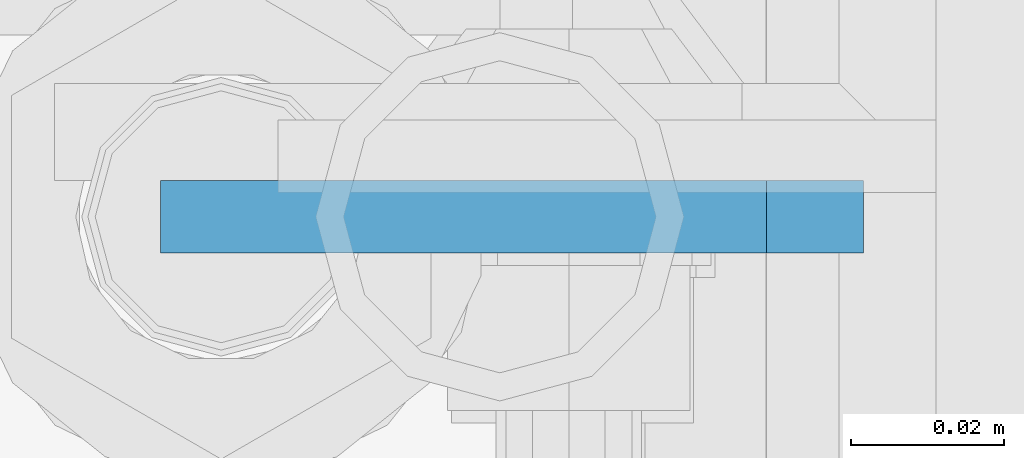
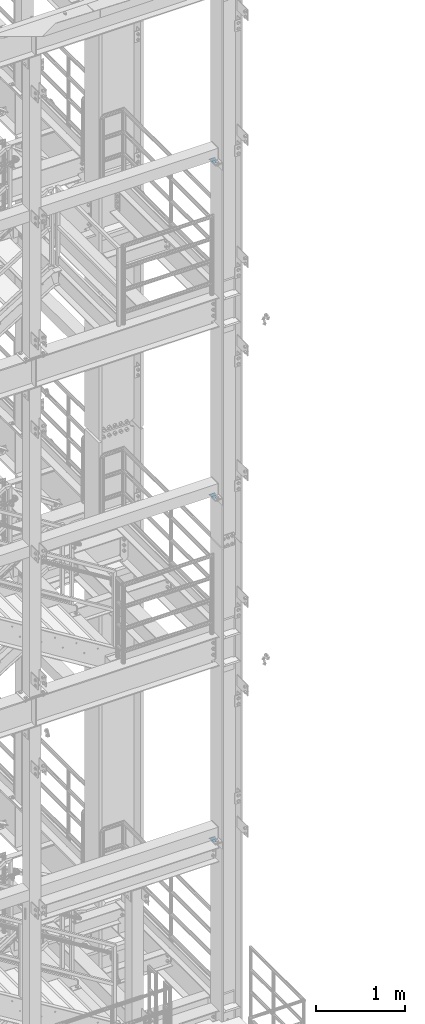
# One storey, part 1454 of 1876: 3 plates, 2 elements without a shape of their own.
"""IFC2X3 building model written with IfcOpenShell, lengths in millimetres."""

from ifc_helpers import new_model, si_unit, frame, origin_with_axes, place, context, subcontext, project, spatial, faceted_brep, material, type_object, element, aggregate, save


model = new_model("IFC2X3")

# Units and contexts
model_context = context("Model", 3, precision=1e-05, world=origin_with_axes())
body_context = subcontext(model_context, "Body", "Model", "MODEL_VIEW")
ifc_project = project(units=[si_unit("LENGTHUNIT", "METRE", prefix="MILLI"), si_unit("AREAUNIT", "SQUARE_METRE"), si_unit("VOLUMEUNIT", "CUBIC_METRE"), si_unit("MASSUNIT", "GRAM", prefix="KILO"), si_unit("TIMEUNIT", "SECOND"), si_unit("PLANEANGLEUNIT", "RADIAN"), si_unit("SOLIDANGLEUNIT", "STERADIAN"), si_unit("THERMODYNAMICTEMPERATUREUNIT", "DEGREE_CELSIUS"), si_unit("LUMINOUSINTENSITYUNIT", "LUMEN")], contexts=[model_context])

# Site, building, storey
site_placement = place(None, origin_with_axes())
site = spatial("IfcSite", under=ifc_project, at=site_placement, CompositionType="ELEMENT")
building_placement = place(site_placement, origin_with_axes())
building = spatial("IfcBuilding", under=site, at=building_placement, Name="Undefined", CompositionType="ELEMENT")
storey_placement = place(building_placement, origin_with_axes())
storey = spatial("IfcBuildingStorey", under=building, at=storey_placement, Name="Undefined", CompositionType="ELEMENT", Elevation=0.0)

# Assembly, plates
assembly_1_placement = place(storey_placement, origin_with_axes())
assembly_1 = element("IfcElementAssembly", 1, at=assembly_1_placement, inside=storey, Name="COLUMN", AssemblyPlace="NOTDEFINED", PredefinedType="RIGID_FRAME")
ifc_material = material(Name="STEEL/A36")
plate_type = type_object("IfcPlateType", PredefinedType="NOTDEFINED")
plate_1_placement = place(assembly_1_placement, frame((7383.46249959391, -7112.0, 19862.8), z_axis=(0.707106779186547, 0.0, 0.707106783186548), x_axis=(0.707106783186548, 4.99999675792934e-09, -0.707106779186547)))
plate_1 = element("IfcPlate", 2, at=plate_1_placement, type_object=plate_type, material=ifc_material, Name="PLATE", context=body_context, shape_type="Brep", body=[
    faceted_brep([(0.0, -4.76249999999982, 0.0), (56.1266013136901, -4.76249999997708, 56.1266013135391), (56.1266013136883, 4.76250000002256, 56.1266013135428), (0.0, 4.76249999999982, 0.0), (74.0871132860975, -4.7624999999698, 56.1266013135246), (74.0871132860993, 4.76250000002983, 56.1266013135282), (130.213714599717, -4.76249999994707, -1.30967237055302e-10), (130.213714599715, 4.76250000005257, -1.23691279441118e-10)], [[[0, 1, 2, 3]], [[1, 4, 5, 2]], [[4, 6, 7, 5]], [[6, 0, 3, 7]], [[5, 7, 3, 2]], [[6, 4, 1, 0]]]),
])
plate_2_placement = place(assembly_1_placement, frame((7383.46249959391, -7112.0, 15240.0), z_axis=(0.707106779186547, 0.0, 0.707106783186548), x_axis=(0.707106783186548, 4.99999675792934e-09, -0.707106779186547)))
plate_2 = element("IfcPlate", 3, at=plate_2_placement, type_object=plate_type, material=ifc_material, Name="PLATE", context=body_context, shape_type="Brep", body=[
    faceted_brep([(0.0, -4.76249999999982, 0.0), (56.1266013136901, -4.76249999997708, 56.1266013135391), (56.1266013136883, 4.76250000002256, 56.1266013135428), (0.0, 4.76249999999982, 0.0), (74.0871132860975, -4.7624999999698, 56.1266013135246), (74.0871132860993, 4.76250000002983, 56.1266013135282), (130.213714599717, -4.76249999994707, -1.30967237055302e-10), (130.213714599715, 4.76250000005257, -1.23691279441118e-10)], [[[0, 1, 2, 3]], [[1, 4, 5, 2]], [[4, 6, 7, 5]], [[6, 0, 3, 7]], [[5, 7, 3, 2]], [[6, 4, 1, 0]]]),
])
aggregate(assembly_1, [plate_1, plate_2])

# Assembly, plate
assembly_2_placement = place(storey_placement, origin_with_axes())
assembly_2 = element("IfcElementAssembly", 4, at=assembly_2_placement, inside=storey, Name="COLUMN", AssemblyPlace="NOTDEFINED", PredefinedType="RIGID_FRAME")
plate_3_placement = place(assembly_2_placement, frame((7383.48174194275, -7112.0, 10502.9), z_axis=(0.707106779186547, 0.0, 0.707106783186548), x_axis=(0.707106783186548, 4.99999675792934e-09, -0.707106779186547)))
plate_3 = element("IfcPlate", 5, at=plate_3_placement, type_object=plate_type, material=ifc_material, Name="PLATE", context=body_context, shape_type="Brep", body=[
    faceted_brep([(0.0, -4.76249999999982, 0.0), (56.1266013136901, -4.76249999997708, 56.1266013135391), (56.1266013136883, 4.76250000002256, 56.1266013135428), (0.0, 4.76249999999982, 0.0), (74.0871132860975, -4.7624999999698, 56.1266013135246), (74.0871132860993, 4.76250000002983, 56.1266013135282), (130.213714599717, -4.76249999994707, -1.30967237055302e-10), (130.213714599715, 4.76250000005257, -1.23691279441118e-10)], [[[0, 1, 2, 3]], [[1, 4, 5, 2]], [[4, 6, 7, 5]], [[6, 0, 3, 7]], [[5, 7, 3, 2]], [[6, 4, 1, 0]]]),
])
aggregate(assembly_2, [plate_3])

save(model, "model.ifc")
